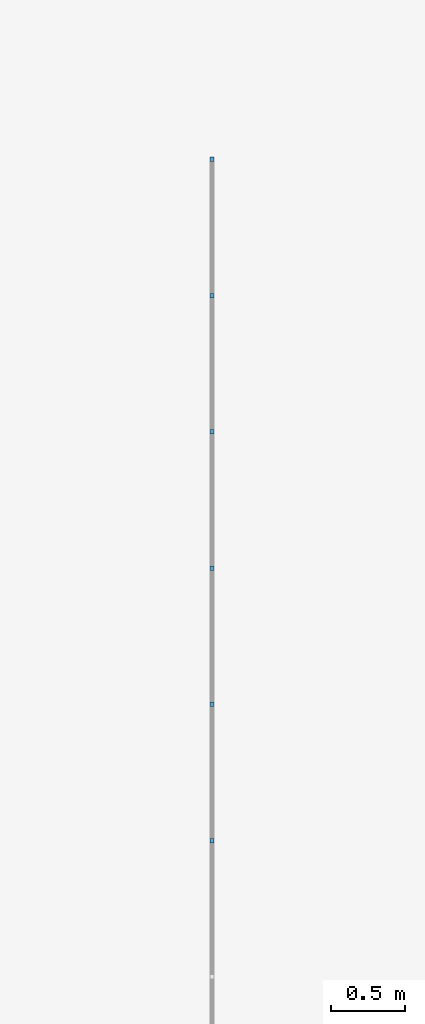
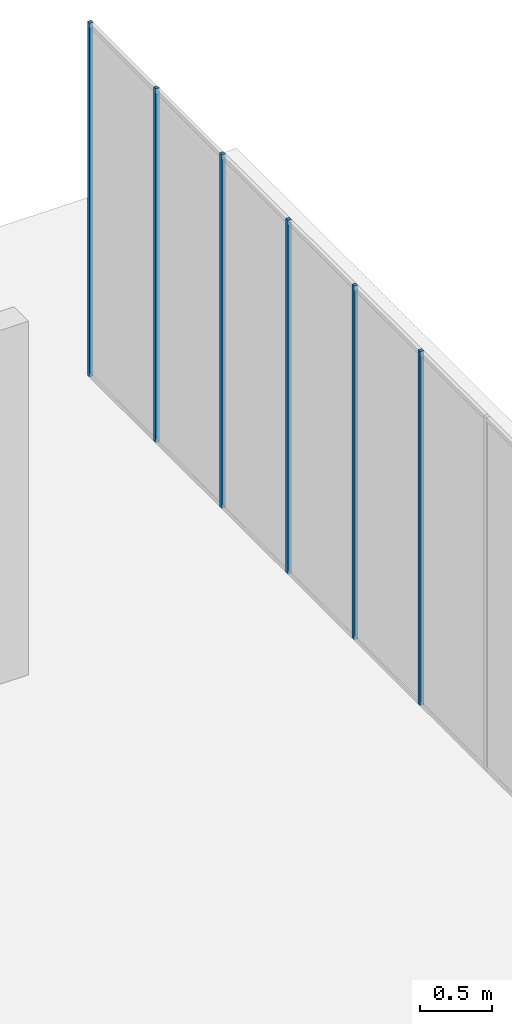
# One storey, part 6 of 8: 6 members, 1 element without a shape of its own.
"""IFC2X3 building model written with IfcOpenShell, lengths in millimetres."""

from ifc_helpers import new_model, entity, si_unit, converted_unit, direction, frame, frame_2d, origin, place, context, subcontext, project, spatial, rectangle, extrude, element, aggregate, save


model = new_model("IFC2X3")

# Units and contexts
model_context = context("Model", 3, precision=1e-06, world=origin(), true_north=direction((2.0, 6.12303176911189e-17, 1.0)))
context_of_model = context(None, 3, precision=1e-06, world=origin(), true_north=direction((2.0, 6.12303176911189e-17, 1.0)))
body_context = subcontext(model_context, "Body", "Model", "MODEL_VIEW")
ifc_project = project(units=[si_unit("LENGTHUNIT", "METRE", prefix="MILLI"), si_unit("AREAUNIT", "SQUARE_METRE", prefix="MILLI"), si_unit("VOLUMEUNIT", "CUBIC_METRE", prefix="MILLI"), converted_unit("PLANEANGLEUNIT", "DEGREE", entity("IfcRatioMeasure", 0.0174532925199433), si_unit("PLANEANGLEUNIT", "RADIAN"), dimensions=[0, 0, 0, 0, 0, 0, 0]), si_unit("TIMEUNIT", "SECOND")], contexts=[model_context, context_of_model])

# Site, building, storey
site_placement = place(None, origin())
site = spatial("IfcSite", under=ifc_project, at=site_placement, CompositionType="ELEMENT")
building_placement = place(site_placement, origin())
building = spatial("IfcBuilding", under=site, at=building_placement, CompositionType="ELEMENT")
storey_placement = place(building_placement, frame((0.0, 0.0, 1500.0)))
storey = spatial("IfcBuildingStorey", under=building, at=storey_placement, Name="Level 1", CompositionType="ELEMENT", Elevation=1500.0)

# Curtain wall, members
curtain_wall_placement = place(storey_placement, origin())
curtain_wall = element("IfcCurtainWall", 1, at=curtain_wall_placement, inside=storey, Name="Curtain Wall:Curtain Wall", ObjectType="Curtain Wall:Curtain Wall:334")
member_1_placement = place(storey_placement, origin())
member_1 = element("IfcMember", 2, at=member_1_placement, Name="Curtain Wall:Curtain Wall:8490", ObjectType="Curtain Wall:Curtain Wall:8490", context=body_context, shape_type="SweptSolid", body=[
    extrude(rectangle(XDim=29.9999999999997, YDim=30.0, at=frame_2d((-1.08268949361445e-12, -1.35891298214119e-13), x_axis=(1.0, 0.0))), frame((18734.4440927411, -1568.75, 0.0)), (0.0, 0.0, 1.0), 3000.0),
])
member_2_placement = place(storey_placement, origin())
member_2 = element("IfcMember", 3, at=member_2_placement, Name="Curtain Wall:Curtain Wall:8490", ObjectType="Curtain Wall:Curtain Wall:8490", context=body_context, shape_type="SweptSolid", body=[
    extrude(rectangle(XDim=29.9999999999997, YDim=30.0000000000001, at=frame_2d((-1.08268949361445e-12, 0.0), x_axis=(1.0, 0.0))), frame((18734.4440927411, -650.0, 0.0)), (0.0, 0.0, 1.0), 3000.0),
])
member_3_placement = place(storey_placement, origin())
member_3 = element("IfcMember", 4, at=member_3_placement, Name="Curtain Wall:Curtain Wall:8490", ObjectType="Curtain Wall:Curtain Wall:8490", context=body_context, shape_type="SweptSolid", body=[
    extrude(rectangle(XDim=29.9999999999997, YDim=30.0, at=frame_2d((-1.08357767203415e-12, 3.37507799486048e-14), x_axis=(1.0, 0.0))), frame((18734.4440927411, 268.75, 0.0)), (0.0, 0.0, 1.0), 3000.0),
])
member_4_placement = place(storey_placement, origin())
member_4 = element("IfcMember", 5, at=member_4_placement, Name="Curtain Wall:Curtain Wall:8490", ObjectType="Curtain Wall:Curtain Wall:8490", context=body_context, shape_type="SweptSolid", body=[
    extrude(rectangle(XDim=29.9999999999997, YDim=30.0000000000001, at=frame_2d((1.08268949361445e-12, 0.0), x_axis=(1.0, 0.0))), frame((18734.4440927411, 1187.5, 0.0)), (0.0, 0.0, 1.0), 3000.0),
])
member_5_placement = place(storey_placement, origin())
member_5 = element("IfcMember", 6, at=member_5_placement, Name="Curtain Wall:Curtain Wall:8490", ObjectType="Curtain Wall:Curtain Wall:8490", context=body_context, shape_type="SweptSolid", body=[
    extrude(rectangle(XDim=29.9999999999997, YDim=30.0, at=frame_2d((1.08268949361445e-12, 1.35891298214119e-13), x_axis=(1.0, 0.0))), frame((18734.4440927411, 2106.25, 0.0)), (0.0, 0.0, 1.0), 3000.0),
])
member_6_placement = place(storey_placement, origin())
member_6 = element("IfcMember", 7, at=member_6_placement, Name="Curtain Wall:Curtain Wall:8490", ObjectType="Curtain Wall:Curtain Wall:8490", context=body_context, shape_type="SweptSolid", body=[
    extrude(rectangle(XDim=29.9999999999997, YDim=29.9999999999997, at=frame_2d((2.70894418008538e-13, 1.08268949361445e-12), x_axis=(1.0, 0.0))), frame((18734.4440927411, 3025.0, 0.0), z_axis=(0.0, 0.0, 1.0), x_axis=(0.0, -1.0, 0.0)), (0.0, 0.0, 1.0), 3000.0),
])
aggregate(curtain_wall, [member_1, member_2, member_3, member_4, member_5, member_6])

save(model, "model.ifc")
